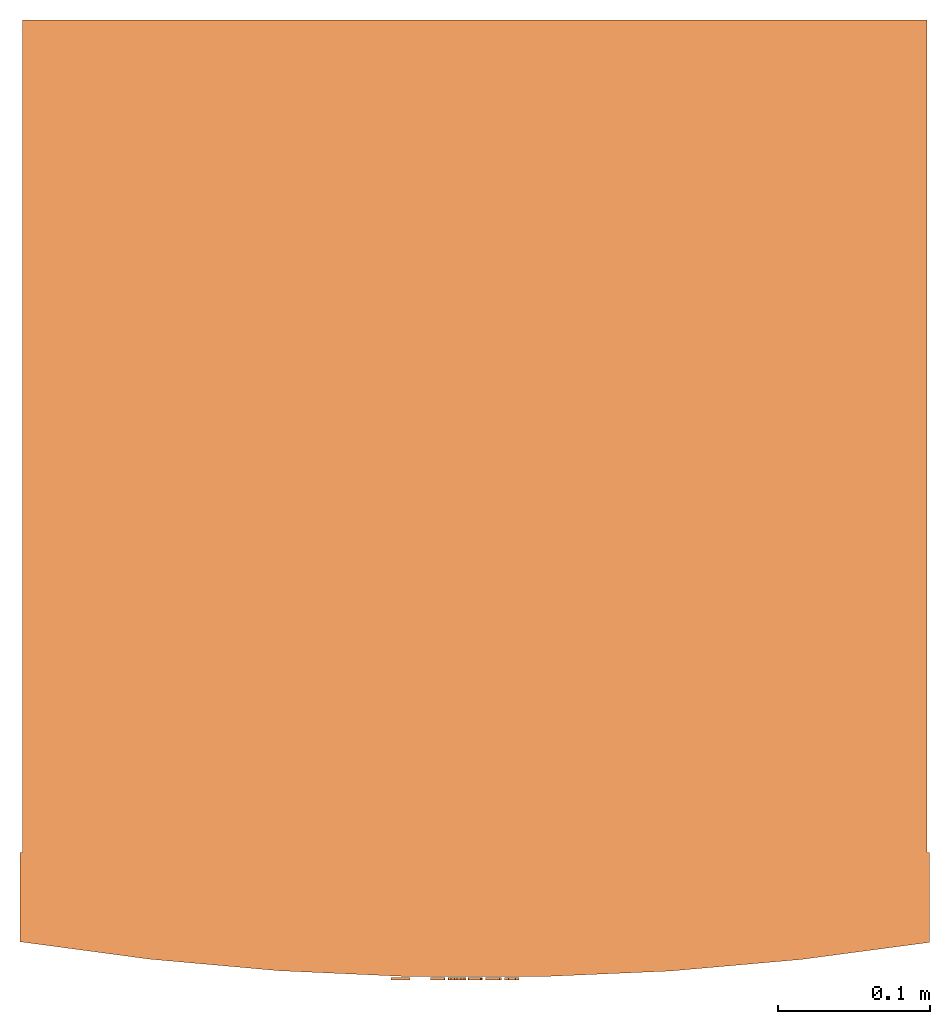
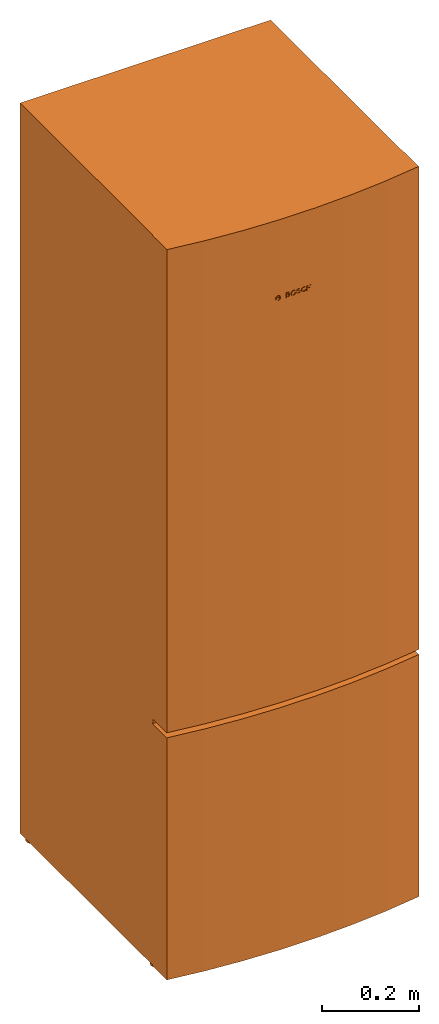
# One storey: 1 proxy.
"""IFC2X3 building model written with IfcOpenShell, lengths in millimetres."""

from ifc_helpers import new_model, entity, si_unit, converted_unit, direction, frame, frame_2d, origin, origin_2d_with_axis, place, context, subcontext, project, spatial, polyline, circle_curve, parameter, trimmed, segment, composite_curve, rectangle, circle, outline, extrude, source, transform, mapped, material, material_list, element, save


model = new_model("IFC2X3")

# Units and contexts
model_context = context("Model", 3, precision=1e-06, world=origin(), true_north=direction((2.0, 6.12303176911189e-17, 1.0)))
context_of_model = context(None, 3, precision=1e-06, world=origin(), true_north=direction((2.0, 6.12303176911189e-17, 1.0)))
body_context = subcontext(model_context, "Body", "Model", "MODEL_VIEW")
ifc_project = project(units=[si_unit("LENGTHUNIT", "METRE", prefix="MILLI"), si_unit("AREAUNIT", "SQUARE_METRE", prefix="MILLI"), si_unit("VOLUMEUNIT", "CUBIC_METRE", prefix="MILLI"), converted_unit("PLANEANGLEUNIT", "DEGREE", entity("IfcRatioMeasure", 0.0174532925199433), si_unit("PLANEANGLEUNIT", "RADIAN"), dimensions=[0, 0, 0, 0, 0, 0, 0]), si_unit("TIMEUNIT", "SECOND")], contexts=[model_context, context_of_model])

# Site, building, storey
site_placement = place(None, origin())
site = spatial("IfcSite", under=ifc_project, at=site_placement, CompositionType="ELEMENT")
building_placement = place(site_placement, origin())
building = spatial("IfcBuilding", under=site, at=building_placement, CompositionType="ELEMENT")
storey_placement = place(building_placement, origin())
storey = spatial("IfcBuildingStorey", under=building, at=storey_placement, Name="Ground Floor", CompositionType="ELEMENT", Elevation=0.0)

# Proxy
ifc_material_1 = material(Name="Polished_Chrome")
ifc_material_2 = material(Name="Matte Black")
ifc_material_3 = material(Name="Polished Grey")
ifc_material_4 = material(Name="Mat Grey")
ifc_material_list = material_list([ifc_material_1, ifc_material_2, ifc_material_3, ifc_material_4])
shared_shape = source(origin(), body_context, "Body", "SweptSolid", [
    extrude(outline(composite_curve([segment(polyline([(1.52571565881409, -1.95538573265073), (1.52571565881407, 1.95538573265078)]), True, "CONTINUOUS"), segment(polyline([(1.52571565881407, 1.95538573265078), (4.3540404774253, 1.9553857326508)]), True, "CONTINUOUS"), segment(trimmed(circle_curve(frame_2d((-0.00514849796854679, -0.256836288070645), x_axis=(0.0, 1.0)), 4.88840002374597), [parameter(296.907099689461)], [parameter(63.0929003105388)], True, "PARAMETER"), True, "CONTINUOUS"), segment(polyline([(-4.36433747336242, 1.95538573265078), (-1.51541866287563, 1.95538573265077)]), True, "CONTINUOUS"), segment(polyline([(-1.51541866287563, 1.95538573265077), (-1.51541866287561, -1.95538573265083)]), True, "CONTINUOUS"), segment(polyline([(-1.51541866287561, -1.95538573265083), (-4.3643374733624, -1.95538573265085)]), True, "CONTINUOUS"), segment(trimmed(circle_curve(frame_2d((-0.00514849796854941, 0.180983504243379), x_axis=(0.0, 1.0)), 4.85454447291834), [parameter(116.108739844468)], [parameter(243.891260155532)], True, "PARAMETER"), True, "CONTINUOUS"), segment(polyline([(4.35404047742533, -1.95538573265074), (1.52571565881409, -1.95538573265073)]), True, "CONTINUOUS")], self_intersect=False), holes=[composite_curve([segment(polyline([(-3.11321584805772, -2.61050562858594), (3.10291998758932, -2.61050562858589)]), True, "CONTINUOUS"), segment(trimmed(circle_curve(frame_2d((-0.00514793023421699, 0.182994630354905), x_axis=(0.0, 1.0)), 4.17896277543917), [parameter(131.948885669245)], [parameter(228.051114330755)], True, "PARAMETER"), False, "CONTINUOUS")], self_intersect=False), composite_curve([segment(polyline([(3.10291998758974, 2.61050562858579), (-3.11321584805843, 2.61050562858579)]), True, "CONTINUOUS"), segment(trimmed(circle_curve(frame_2d((-0.00514793023421439, -0.251557385317121), x_axis=(0.0, 1.0)), 4.22510246945063), [parameter(312.640407966491)], [parameter(47.3595920335093)], True, "PARAMETER"), False, "CONTINUOUS")], self_intersect=False)]), frame((-48.9476562626026, -358.672139699208, 1655.68152192326), z_axis=(0.0, -1.0, 0.0), x_axis=(0.0, 0.0, -1.0)), (0.0, 0.0, -1.0), 1.56080041448983),
    extrude(outline(composite_curve([segment(trimmed(circle_curve(origin_2d_with_axis(), 6.18299399007748), [parameter(0.0)], [parameter(180.0)], True, "PARAMETER"), True, "CONTINUOUS"), segment(trimmed(circle_curve(origin_2d_with_axis(), 6.18299399007748), [parameter(180.0)], [parameter(0.0)], True, "PARAMETER"), True, "CONTINUOUS")], self_intersect=False), holes=[composite_curve([segment(trimmed(circle_curve(origin_2d_with_axis(), 5.43670988276651), [parameter(180.0)], [parameter(0.0)], True, "PARAMETER"), False, "CONTINUOUS"), segment(trimmed(circle_curve(origin_2d_with_axis(), 5.43670988276651), [parameter(0.0)], [parameter(180.0)], True, "PARAMETER"), False, "CONTINUOUS")], self_intersect=False)]), frame((-48.9526523239277, -358.672139699208, 1655.68666928576), z_axis=(0.0, 1.0, 0.0), x_axis=(1.0, 0.0, 0.0)), (0.0, 0.0, 1.0), 1.56080041448983),
    extrude(outline(composite_curve([segment(polyline([(-6.35271415550415, -3.86875626653848), (6.19090871558933, -3.86875626653848)]), True, "CONTINUOUS"), segment(polyline([(6.19090871558933, -3.86875626653848), (6.13612975337333, 2.57917084435899)]), True, "CONTINUOUS"), segment(trimmed(circle_curve(frame_2d((3.25725979770914, 2.57917084435897), x_axis=(0.0, 1.0)), 2.87886995566409), [parameter(270.0)], [parameter(90.0000000000003)], True, "PARAMETER"), True, "CONTINUOUS"), segment(trimmed(circle_curve(frame_2d((-2.98716215672948, 2.57917084435898), x_axis=(0.0, 1.0)), 3.36555199877475), [parameter(270.0)], [parameter(90.0000000000004)], True, "PARAMETER"), True, "CONTINUOUS"), segment(polyline([(-6.35271415550415, 2.57917084435898), (-6.35271415550415, -3.86875626653848)]), True, "CONTINUOUS")], self_intersect=False), holes=[composite_curve([segment(polyline([(4.09595517520506, -1.42202706130533), (1.20007162058823, -1.42202706130533)]), True, "CONTINUOUS"), segment(polyline([(1.20007162058823, -1.42202706130533), (1.20007162058823, 2.0812304920711)]), True, "CONTINUOUS"), segment(trimmed(circle_curve(frame_2d((2.62714850959105, 2.0812304920711), x_axis=(0.0, 1.0)), 1.42707688900283), [parameter(270.0)], [parameter(90.0000000000001)], True, "PARAMETER"), False, "CONTINUOUS"), segment(polyline([(4.05422539859387, 2.08123049207242), (4.09595517520506, -1.42202706130533)]), True, "CONTINUOUS")], self_intersect=False), composite_curve([segment(polyline([(-0.892272082674936, -1.42202706130533), (-3.78815563729177, -1.42202706130533)]), True, "CONTINUOUS"), segment(polyline([(-3.78815563729177, -1.42202706130533), (-3.78815563729177, 2.08123049207413)]), True, "CONTINUOUS"), segment(trimmed(circle_curve(frame_2d((-2.36107874828895, 2.08123049207413), x_axis=(0.0, 1.0)), 1.42707688900283), [parameter(270.0)], [parameter(89.9999999999999)], True, "PARAMETER"), False, "CONTINUOUS"), segment(polyline([(-0.934001859286127, 2.08123049207548), (-0.892272082674936, -1.42202706130533)]), True, "CONTINUOUS")], self_intersect=False)]), frame((-25.4923446988317, -358.698839284717, 1656.11355273851), z_axis=(0.0, 1.0, 0.0), x_axis=(0.0, 0.0, 1.0)), (0.0, 0.0, 1.0), 1.58750000000208),
    extrude(outline(polyline([(-4.84293711903845, -6.17701957369656), (-2.39869347296806, -6.17701957369656), (-2.39869347296806, -1.24619492381565), (2.39871188451743, -1.24619492381565), (2.39871188451743, -6.17701957369656), (4.84290029593969, -6.17701957369656), (4.84290029593969, 6.36660329739695), (2.39871188451745, 6.36660329739695), (2.39871188451745, 0.867027476414861), (-2.39869347296806, 0.867027476414861), (-2.39869347296806, 6.36660329739695), (-4.84293711903845, 6.36660329739695), (-4.84293711903845, -6.17701957369656)])), frame((24.4871758425006, -358.698839284717, 1656.12744188041), z_axis=(0.0, 1.0, 0.0), x_axis=(1.0, 0.0, 0.0)), (0.0, 0.0, 1.0), 1.58750000000208),
    extrude(outline(polyline([(-6.6802742430129, 1.04182802250549), (-4.13923265919031, 1.04182802250549), (-3.6597776054062, 2.59583195884343), (-3.10570535714655, 3.2976515514293), (-2.49888856039489, 3.63890927838529), (-1.82524317983398, 3.76989942539929), (-1.09426782669458, 3.73909911783326), (-0.350815158237827, 3.54243240234897), (0.270067716178781, 3.21170584048513), (0.670879483493625, 2.79889855086622), (0.955638563908334, 2.3534810741879), (1.20826510151277, 1.86301779125678), (1.45977052909905, 1.2842979599416), (1.70520543908354, 0.577605081925983), (1.92021924553665, -0.24474280416821), (2.05315144916109, -1.08604349787526), (2.05808944160682, -1.85528131059992), (1.93855206918853, -2.54191012909582), (1.71631679806062, -3.16491086271248), (1.40800803432368, -3.71522435782504), (1.02066070189774, -4.13221514928649), (0.535009628427274, -4.38627214955513), (-0.13304342919852, -4.54159953732846), (-1.0579311182039, -4.62288231842062), (-2.15094957801441, -4.20958907868194), (-3.24353259699984, -2.66323577945752), (-5.45292808777341, -4.03509002652935), (-3.3469080769988, -6.32175281618276), (-1.53746073103957, -7.00891916884998), (-0.00669775974628352, -6.88693920371651), (1.27101452897323, -6.52047428889677), (2.33885229149461, -5.96302615426288), (3.23833705232308, -5.19937206514157), (3.95148198610037, -4.23820035273195), (4.4152110069715, -3.10635267348489), (4.60023387718375, -1.86841106052828), (4.58176833238456, -0.700600307416877), (4.43307572402014, 0.284031696050863), (4.14404153089514, 1.29915890874403), (3.67965136356495, 2.53798029516076), (2.98499873345168, 3.75895258676738), (2.09708080307446, 4.6935586771158), (1.27301185312385, 5.30696866796606), (0.287896788771207, 5.69147769148197), (-0.995428659972935, 5.92702162333704), (-2.00888010005206, 5.90202193234818), (-3.26706517861991, 5.6306391121974), (-4.41251104824675, 5.14111381954245), (-5.25564522013206, 4.54320756233107), (-5.99330389889207, 3.54042644177813), (-6.6802742430129, 1.04182802250549)])), frame((11.2713403976769, -358.698839284717, 1656.21218426696), z_axis=(0.0, 1.0, 0.0), x_axis=(-0.970269687026535, 0.0, -0.242026309391002)), (0.0, 0.0, 1.0), 1.58750000000208),
    extrude(outline(polyline([(-1.74098400068303, -6.37570825535927), (1.13288434472348, -6.37570825535927), (3.74722253949025, -4.91511032967016), (5.50311720938685, -2.32851986095425), (5.99831404636468, 0.791506446199914), (5.11936942284088, 3.73020816521622), (3.06763895963387, 5.81436414746325), (1.74098400068301, 6.37570825535928), (-1.13288434472347, 6.37570825535927), (-3.74722253949025, 4.91511032967016), (-5.50311720938685, 2.32851986095425), (-5.99831404636468, -0.791506446199914), (-5.11936942284087, -3.73020816521622), (-3.06763895963385, -5.81436414746326), (-1.74098400068303, -6.37570825535927)]), holes=[polyline([(-1.04130742428706, -4.24598246105528), (-1.78258367538808, -3.92850016576755), (-2.94580905056339, -2.72466925768313), (-3.50083600789314, -0.976243318733142), (-3.3377346515192, 0.970480450836644), (-2.4888092053783, 2.72992953346264), (-1.12219976546602, 3.9536234601038), (0.491419908278207, 4.39919464096792), (1.29117639862163, 4.29587453440039), (2.03245264972264, 3.97839223911266), (3.19567802489795, 2.77456133102824), (3.75070498222769, 1.02613539207826), (3.58760362585374, -0.920588377491528), (2.73867817971283, -2.68003746011753), (1.37206873980054, -3.90373138675868), (-0.241550933943688, -4.3493025676228), (-1.04130742428706, -4.24598246105528)])]), frame((-11.8694359979225, -358.698839284717, 1655.95969016667), z_axis=(0.0, 1.0, 0.0), x_axis=(0.964681023593462, 0.0, -0.263420809198267)), (0.0, 0.0, 1.0), 1.58750000000208),
    extrude(outline(polyline([(-2.95649637460541, 0.132251844729778), (-3.24904087068925, 0.379359324118629), (-3.4478090959969, 0.637119458986615), (-3.56146699872779, 0.902512578546612), (-3.59868052708303, 1.17251901201394), (-3.56811562926189, 1.44411908860126), (-3.47843825346472, 1.71429313752277), (-3.33831434789204, 1.98002148799291), (-3.15640986074357, 2.238284469225), (-2.9413907402195, 2.48606241043302), (-2.70192293452005, 2.72033564083097), (-2.44667239184555, 2.93808448963305), (-2.18428966764574, 3.13628836183525), (-1.92069436356611, 3.31176268940703), (-1.65595568288265, 3.46097163234745), (-1.38938753232187, 3.58033400083513), (-1.12030381861139, 3.66626860505026), (-0.848018448477891, 3.71519425517169), (-0.571845328648199, 3.72352976137849), (-0.291098365850086, 3.68769393385108), (-0.0050914668102278, 3.6041055827683), (0.286861461744383, 3.46918351830945), (0.585446513086909, 3.2793465506536), (0.891349780489587, 3.03101348998116), (1.20525735722605, 2.72060314647054), (3.03047425836917, 4.27911794051628), (0.990835632216758, 5.8034334371591), (-1.02668948174524, 5.97899819590885), (-2.83014309317775, 5.34327534027694), (-4.22893045716107, 4.4311297102031), (-5.13903668740937, 3.57428979805403), (-5.65773481149123, 2.75895760410796), (-5.89983325148192, 1.93775396894993), (-5.94727587023151, 1.07562341942931), (-5.80213226908546, 0.167814349227001), (-5.42503910934999, -0.747199393567264), (-4.74320800173872, -1.56491423961755), (-3.87070976763643, -2.17564147366942), (-2.96656587534657, -2.50544645283116), (-2.01869688587091, -2.55867630593718), (-0.931531004884883, -2.36735321238392), (0.321623947390807, -1.99795228524964), (1.57892749665494, -1.57395776309446), (2.67793825558377, -1.30855905209922), (3.49199906112696, -1.44677593471852), (3.90175716282437, -2.08941351787289), (3.61564086932367, -3.14860285990209), (2.78624767713191, -3.90937465741959), (1.7451935923052, -4.29918050465405), (-0.0780336343262001, -3.65977167925302), (-2.02650776679582, -5.13882637267433), (-0.685040560905762, -6.35047124604489), (0.448439968079585, -6.79089927606948), (1.40405776923696, -6.7813043833544), (2.22070545605879, -6.55927885078118), (2.9543191417539, -6.19991991965191), (3.6623537571634, -5.75943370110308), (4.36230567741777, -5.27559064488172), (5.0004091303466, -4.75328301497297), (5.51659167943389, -4.19376327257351), (5.88202149794705, -3.59117935489672), (6.10347370994723, -2.93158171201756), (6.18934826387396, -2.2040522587553), (6.14347135090482, -1.44839159544884), (5.96620444827061, -0.742820947386317), (5.66014592527179, -0.149460446948892), (5.2364165988333, 0.332141097059697), (4.70805235560083, 0.716736092760348), (4.07434535029484, 1.00309317432509), (3.30065793279294, 1.15052107277866), (2.34720862071982, 1.11234631195224), (1.17741443181503, 0.847583394434039), (-0.171359296887876, 0.446751107249639), (-1.58758560583651, 0.132251844729778), (-2.95649637460541, 0.132251844729778)])), frame((0.350185711417441, -358.698839284718, 1655.64732669164), z_axis=(0.0, -1.0, 0.0), x_axis=(-0.820361165006402, 0.0, 0.571845747513558)), (0.0, 0.0, -1.0), 1.58750000000208),
    extrude(circle(Radius=12.7, at=frame_2d((0.0, -3.38395977905748e-14), x_axis=(1.0, 0.0))), frame((280.950629467346, -256.725318581567, 0.0)), (0.0, 0.0, 1.0), 12.331005825579),
    extrude(circle(Radius=12.7, at=frame_2d((0.0, -3.38395977905748e-14), x_axis=(1.0, 0.0))), frame((280.950629467342, 256.725318581591, 0.0)), (0.0, 0.0, 1.0), 12.331005825579),
    extrude(circle(Radius=12.7, at=frame_2d((0.0, -3.38395977905748e-14), x_axis=(1.0, 0.0))), frame((-280.950629467327, -256.725318581576, 0.0)), (0.0, 0.0, 1.0), 12.331005825579),
    extrude(circle(Radius=12.7, at=frame_2d((0.0, 3.38395977905748e-14), x_axis=(1.0, 0.0))), frame((-280.950629467355, 256.725318581582, 0.0)), (0.0, 0.0, 1.0), 12.331005825579),
    extrude(outline(composite_curve([segment(polyline([(-300.037500000003, -29.520644175241), (300.037499999997, -29.520644175241)]), True, "CONTINUOUS"), segment(polyline([(300.037499999997, -29.520644175241), (300.037499999983, 29.3188044543808)]), True, "CONTINUOUS"), segment(trimmed(circle_curve(frame_2d((-1.29116857370079, -1889.81906395545), x_axis=(-1.0, 0.0)), 1942.65002624483), [parameter(261.076697976679)], [parameter(278.846214576591)], True, "PARAMETER"), True, "CONTINUOUS"), segment(polyline([(-300.037500000003, 29.7224838961052), (-300.037500000003, -29.520644175241)]), True, "CONTINUOUS")], self_intersect=False)), frame((0.0, -304.158144175251, 634.631005825582), z_axis=(0.0, 0.0, 1.0), x_axis=(-1.0, 0.0, 0.0)), (0.0, 0.0, 1.0), 1216.39399417442),
    extrude(outline(composite_curve([segment(polyline([(-300.037500000003, -29.520644175241), (300.037499999997, -29.520644175241)]), True, "CONTINUOUS"), segment(polyline([(300.037499999997, -29.520644175241), (300.037499999983, 29.3188044543808)]), True, "CONTINUOUS"), segment(trimmed(circle_curve(frame_2d((-1.29116857370079, -1889.81906395545), x_axis=(-1.0, 0.0)), 1942.65002624483), [parameter(261.076697976679)], [parameter(278.846214576591)], True, "PARAMETER"), True, "CONTINUOUS"), segment(polyline([(-300.037500000003, 29.7224838961052), (-300.037500000003, -29.520644175241)]), True, "CONTINUOUS")], self_intersect=False)), frame((0.0, -304.158144175251, 12.3310058255771), z_axis=(0.0, 0.0, 1.0), x_axis=(-1.0, 0.0, 0.0)), (0.0, 0.0, 1.0), 609.6),
    extrude(rectangle(XDim=596.900000000005, YDim=549.27500000001, at=origin_2d_with_axis()), frame((0.0, 0.0, 12.3310058255771), z_axis=(0.0, 0.0, 1.0), x_axis=(-1.0, 0.0, 0.0)), (0.0, 0.0, 1.0), 1838.69399417442),
])
proxy_placement = place(storey_placement, frame((-5789.06594192557, 1007.38008321253, 0.0)))
element("IfcBuildingElementProxy", 1, at=proxy_placement, inside=storey, material=ifc_material_list, CompositionType="ELEMENT", context=body_context, shape_type="MappedRepresentation", body=[
    mapped(shared_shape, transform((0.0, 0.0, 0.0), scale=1.0)),
])

save(model, "model.ifc")
